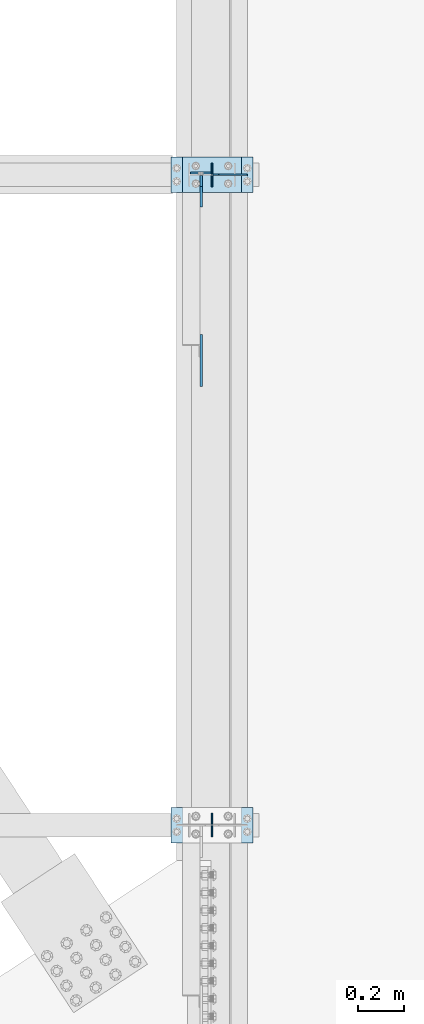
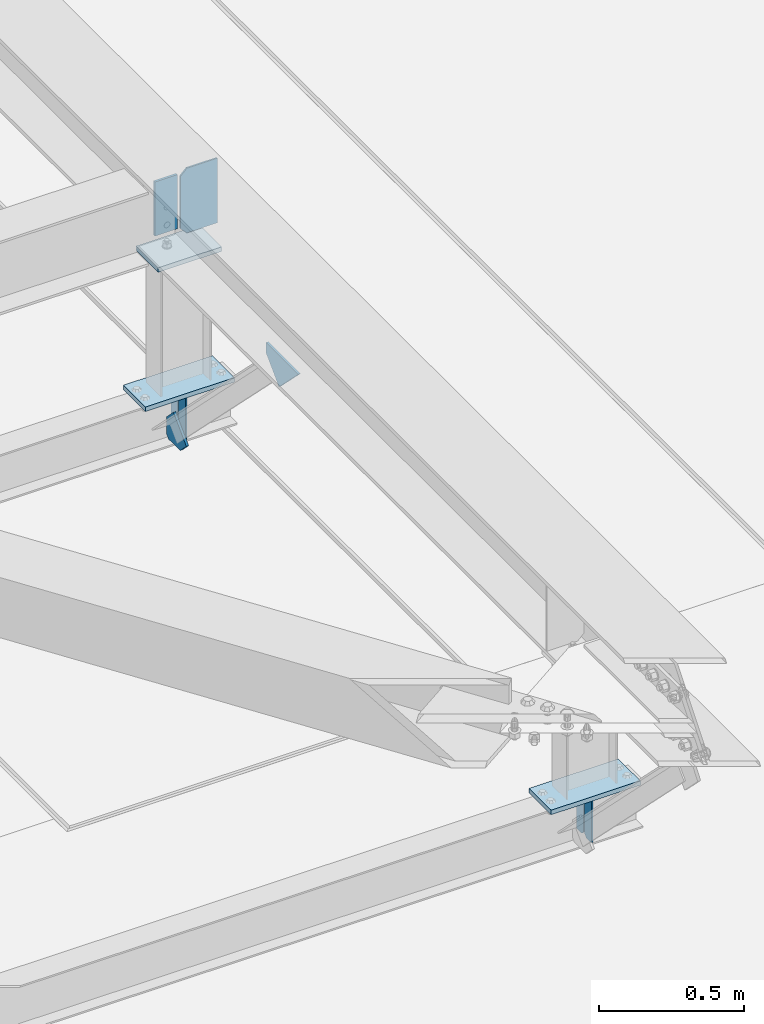
# One storey, part 3266 of 3843: 11 plates, 5 elements without a shape of their own.
"""IFC2X3 building model written with IfcOpenShell, lengths in millimetres."""

from ifc_helpers import new_model, si_unit, frame, origin_with_axes, place, context, subcontext, project, spatial, faceted_brep, material, type_object, element, aggregate, save


model = new_model("IFC2X3")

# Units and contexts
model_context = context("Model", 3, precision=1e-05, world=origin_with_axes())
body_context = subcontext(model_context, "Body", "Model", "MODEL_VIEW")
ifc_project = project(units=[si_unit("LENGTHUNIT", "METRE", prefix="MILLI"), si_unit("AREAUNIT", "SQUARE_METRE"), si_unit("VOLUMEUNIT", "CUBIC_METRE"), si_unit("MASSUNIT", "GRAM", prefix="KILO"), si_unit("TIMEUNIT", "SECOND"), si_unit("PLANEANGLEUNIT", "RADIAN"), si_unit("SOLIDANGLEUNIT", "STERADIAN"), si_unit("THERMODYNAMICTEMPERATUREUNIT", "DEGREE_CELSIUS"), si_unit("LUMINOUSINTENSITYUNIT", "LUMEN")], contexts=[model_context])

# Site, building, storey
site_placement = place(None, origin_with_axes())
site = spatial("IfcSite", under=ifc_project, at=site_placement, CompositionType="ELEMENT")
building_placement = place(site_placement, origin_with_axes())
building = spatial("IfcBuilding", under=site, at=building_placement, Name="Undefined", CompositionType="ELEMENT")
storey_placement = place(building_placement, origin_with_axes())
storey = spatial("IfcBuildingStorey", under=building, at=storey_placement, Name="Undefined", CompositionType="ELEMENT", Elevation=0.0)

# Assembly, plate
assembly_1_placement = place(storey_placement, origin_with_axes())
assembly_1 = element("IfcElementAssembly", 1, at=assembly_1_placement, inside=storey, Name="BEAM", AssemblyPlace="NOTDEFINED", PredefinedType="RIGID_FRAME")
ifc_material = material(Name="STEEL/A572-50")
plate_type_1 = type_object("IfcPlateType", PredefinedType="NOTDEFINED")
plate_1_placement = place(assembly_1_placement, frame((42057.6375000001, 54744.9375, 42394.940947973), z_axis=(-1.0, 0.0, 0.0), x_axis=(0.0, 0.0, -1.0)))
plate_1 = element("IfcPlate", 2, at=plate_1_placement, type_object=plate_type_1, material=ifc_material, Name="PLATE", context=body_context, shape_type="Brep", body=[
    faceted_brep([(0.0, -4.76249999999709, 0.0), (0.0, -4.76249999999709, 88.9000015258789), (0.0, 4.76249999999709, 88.9000015258789), (0.0, 4.76249999999709, 0.0), (228.600006102781, -4.7625000004191, 88.9000015257589), (228.600006102781, 4.76249999954598, 88.9000015257443), (228.600006103079, -4.7625000004482, 7.27595761418343e-12), (228.600006103079, 4.76249999954598, -7.27595761418343e-12)], [[[0, 1, 2, 3]], [[1, 4, 5, 2]], [[4, 6, 7, 5]], [[6, 0, 3, 7]], [[5, 7, 3, 2]], [[6, 4, 1, 0]]]),
])

# Assembly, plates
assembly_2_placement = place(storey_placement, origin_with_axes())
assembly_2 = element("IfcElementAssembly", 3, at=assembly_2_placement, inside=storey, Name="BEAM", AssemblyPlace="NOTDEFINED", PredefinedType="RIGID_FRAME")
plate_type_2 = type_object("IfcPlateType", PredefinedType="NOTDEFINED")
plate_2_placement = place(assembly_2_placement, frame((42062.4, 51879.5, 41495.6625), z_axis=(0.0, 0.0, -1.0), x_axis=(0.0, 1.0, 0.0)))
plate_2 = element("IfcPlate", 4, at=plate_2_placement, type_object=plate_type_2, material=ifc_material, Name="PLATE", context=body_context, shape_type="Brep", body=[
    faceted_brep([(0.0, -3.17499999999927, 0.0), (0.0, -3.17500000000291, 187.324999999997), (0.0, 3.17500000000291, 187.324999999997), (0.0, 3.17499999999927, 0.0), (34.9250001907349, -3.17500000000291, 187.324999999997), (34.9250001907349, 3.17500000000291, 187.324999999997), (47.625, -3.17500000000291, 174.625000190732), (47.625, 3.17500000000291, 174.625000190732), (47.625, -3.17499999999927, 12.6999998092651), (47.625, 3.17499999999927, 12.6999998092651), (34.9250001907349, -3.17499999999927, 0.0), (34.9250001907349, 3.17499999999927, 0.0)], [[[0, 1, 2, 3]], [[1, 4, 5, 2]], [[4, 6, 7, 5]], [[6, 8, 9, 7]], [[8, 10, 11, 9]], [[10, 0, 3, 11]], [[5, 7, 9, 11, 3, 2]], [[10, 8, 6, 4, 1, 0]]]),
])
plate_3_placement = place(assembly_2_placement, frame((42062.4, 51981.1, 41495.6625), z_axis=(0.0, 0.0, -1.0), x_axis=(0.0, -1.0, 0.0)))
plate_3 = element("IfcPlate", 5, at=plate_3_placement, type_object=plate_type_2, material=ifc_material, Name="PLATE", context=body_context, shape_type="Brep", body=[
    faceted_brep([(0.0, -3.17499999999927, 0.0), (0.0, -3.17500000000291, 187.324999999997), (0.0, 3.17500000000291, 187.324999999997), (0.0, 3.17499999999927, 0.0), (34.9250001907349, -3.17500000000291, 187.324999999997), (34.9250001907349, 3.17500000000291, 187.324999999997), (47.625, -3.17500000000291, 174.625000190732), (47.625, 3.17500000000291, 174.625000190732), (47.625, -3.17499999999927, 12.6999998092651), (47.625, 3.17499999999927, 12.6999998092651), (34.9250001907349, -3.17499999999927, 0.0), (34.9250001907349, 3.17499999999927, 0.0)], [[[0, 1, 2, 3]], [[1, 4, 5, 2]], [[4, 6, 7, 5]], [[6, 8, 9, 7]], [[8, 10, 11, 9]], [[10, 0, 3, 11]], [[5, 7, 9, 11, 3, 2]], [[10, 8, 6, 4, 1, 0]]]),
])
aggregate(assembly_2, [plate_2, plate_3])

assembly_3_placement = place(storey_placement, origin_with_axes())
assembly_3 = element("IfcElementAssembly", 6, at=assembly_3_placement, inside=storey, Name="BEAM", AssemblyPlace="NOTDEFINED", PredefinedType="RIGID_FRAME")
plate_4_placement = place(assembly_3_placement, frame((42062.4, 54686.2, 41495.6625), z_axis=(0.0, 0.0, -1.0), x_axis=(0.0, 1.0, 0.0)))
plate_4 = element("IfcPlate", 7, at=plate_4_placement, type_object=plate_type_2, material=ifc_material, Name="PLATE", context=body_context, shape_type="Brep", body=[
    faceted_brep([(0.0, -3.17499999999927, 0.0), (0.0, -3.17500000000291, 187.324999999997), (0.0, 3.17500000000291, 187.324999999997), (0.0, 3.17499999999927, 0.0), (34.9250001907349, -3.17500000000291, 187.324999999997), (34.9250001907349, 3.17500000000291, 187.324999999997), (47.625, -3.17500000000291, 174.625000190732), (47.625, 3.17500000000291, 174.625000190732), (47.625, -3.17499999999927, 12.6999998092651), (47.625, 3.17499999999927, 12.6999998092651), (34.9250001907349, -3.17499999999927, 0.0), (34.9250001907349, 3.17499999999927, 0.0)], [[[0, 1, 2, 3]], [[1, 4, 5, 2]], [[4, 6, 7, 5]], [[6, 8, 9, 7]], [[8, 10, 11, 9]], [[10, 0, 3, 11]], [[5, 7, 9, 11, 3, 2]], [[10, 8, 6, 4, 1, 0]]]),
])
plate_5_placement = place(assembly_3_placement, frame((42062.4, 54787.8, 41495.6625), z_axis=(0.0, 0.0, -1.0), x_axis=(0.0, -1.0, 0.0)))
plate_5 = element("IfcPlate", 8, at=plate_5_placement, type_object=plate_type_2, material=ifc_material, Name="PLATE", context=body_context, shape_type="Brep", body=[
    faceted_brep([(0.0, -3.17499999999927, 0.0), (0.0, -3.17500000000291, 187.324999999997), (0.0, 3.17500000000291, 187.324999999997), (0.0, 3.17499999999927, 0.0), (34.9250001907349, -3.17500000000291, 187.324999999997), (34.9250001907349, 3.17500000000291, 187.324999999997), (47.625, -3.17500000000291, 174.625000190732), (47.625, 3.17500000000291, 174.625000190732), (47.625, -3.17499999999927, 12.6999998092651), (47.625, 3.17499999999927, 12.6999998092651), (34.9250001907349, -3.17499999999927, 0.0), (34.9250001907349, 3.17499999999927, 0.0)], [[[0, 1, 2, 3]], [[1, 4, 5, 2]], [[4, 6, 7, 5]], [[6, 8, 9, 7]], [[8, 10, 11, 9]], [[10, 0, 3, 11]], [[5, 7, 9, 11, 3, 2]], [[10, 8, 6, 4, 1, 0]]]),
])

# Assembly, plate
assembly_4_placement = place(storey_placement, origin_with_axes())
assembly_4 = element("IfcElementAssembly", 9, at=assembly_4_placement, inside=storey, Name="POST", AssemblyPlace="NOTDEFINED", PredefinedType="RIGID_FRAME")
plate_type_3 = type_object("IfcPlateType", PredefinedType="NOTDEFINED")
plate_6_placement = place(assembly_4_placement, frame((41935.3999969006, 54813.2007403097, 42083.0375000289), z_axis=(0.0, -0.999999996977702, -7.77469999939545e-05), x_axis=(1.0, 0.0, 0.0)))
plate_6 = element("IfcPlate", 10, at=plate_6_placement, type_object=plate_type_3, material=ifc_material, Name="PLATE", context=body_context, shape_type="Brep", body=[
    faceted_brep([(0.0, -9.52500000000146, 0.0), (0.0, -9.5249999999287, 152.40000000162), (0.0, 9.52500000002328, 152.40000000162), (0.0, 9.52500000000146, 0.0), (254.0, -9.5249999999287, 152.40000000162), (254.0, 9.52500000002328, 152.40000000162), (253.999999999998, -9.52500000000146, 0.0), (253.999999999998, 9.52500000000146, 0.0)], [[[0, 1, 2, 3]], [[1, 4, 5, 2]], [[4, 6, 7, 5]], [[6, 0, 3, 7]], [[5, 7, 3, 2]], [[6, 4, 1, 0]]]),
])

assembly_5_placement = place(storey_placement, origin_with_axes())
assembly_5 = element("IfcElementAssembly", 11, at=assembly_5_placement, inside=storey, Name="POST", AssemblyPlace="NOTDEFINED", PredefinedType="RIGID_FRAME")
plate_7_placement = place(assembly_5_placement, frame((42240.2, 51854.1, 41513.125), z_axis=(-1.0, 0.0, 0.0), x_axis=(0.0, 1.0, 0.0)))
plate_7 = element("IfcPlate", 12, at=plate_7_placement, type_object=plate_type_3, material=ifc_material, Name="PLATE", context=body_context, shape_type="Brep", body=[
    faceted_brep([(0.0, -9.52500000000146, 0.0), (0.0, -9.52500000000146, 355.599999999999), (0.0, 9.52500000000146, 355.599999999999), (0.0, 9.52500000000146, 0.0), (152.399999999994, -9.52500000000146, 355.599999999999), (152.399999999994, 9.52500000000146, 355.599999999999), (152.400000000001, -9.52500000000146, 0.0), (152.400000000001, 9.52500000000146, 0.0)], [[[0, 1, 2, 3]], [[1, 4, 5, 2]], [[4, 6, 7, 5]], [[6, 0, 3, 7]], [[5, 7, 3, 2]], [[6, 4, 1, 0]]]),
])
aggregate(assembly_5, [plate_7])

# Plate
plate_8_placement = place(assembly_4_placement, frame((42240.2, 54660.8, 41513.125), z_axis=(-1.0, 0.0, 0.0), x_axis=(0.0, 1.0, 0.0)))
plate_8 = element("IfcPlate", 13, at=plate_8_placement, type_object=plate_type_3, material=ifc_material, Name="PLATE", context=body_context, shape_type="Brep", body=[
    faceted_brep([(0.0, -9.52500000000146, 0.0), (0.0, -9.52500000000146, 355.599999999999), (0.0, 9.52500000000146, 355.599999999999), (0.0, 9.52500000000146, 0.0), (152.399999999994, -9.52500000000146, 355.599999999999), (152.399999999994, 9.52500000000146, 355.599999999999), (152.400000000001, -9.52500000000146, 0.0), (152.400000000001, 9.52500000000146, 0.0)], [[[0, 1, 2, 3]], [[1, 4, 5, 2]], [[4, 6, 7, 5]], [[6, 0, 3, 7]], [[5, 7, 3, 2]], [[6, 4, 1, 0]]]),
])

aggregate(assembly_4, [plate_6, plate_8])

plate_type_4 = type_object("IfcPlateType", PredefinedType="NOTDEFINED")
plate_9_placement = place(assembly_1_placement, frame((42016.3625, 53824.0897610718, 42123.4142163618), z_axis=(0.0, 0.707106781186548, 0.707106781186548), x_axis=(5.70000238222118e-08, 0.707106781186546, -0.707106781186546)))
plate_9 = element("IfcPlate", 14, at=plate_9_placement, type_object=plate_type_4, material=ifc_material, Name="PLATE", context=body_context, shape_type="Brep", body=[
    faceted_brep([(0.0, -4.76249999999709, 0.0), (157.726597423803, -4.76249999999709, 157.726601438866), (157.726597423803, 4.76249999999709, 157.726601438866), (0.0, 4.76249999999709, 0.0), (188.387110059113, -4.76249999999709, 127.066089584019), (188.387110059113, 4.76249999999709, 127.066089584019), (188.387111679331, -4.76249999999709, 1.09139364212751e-10), (188.387111679331, 4.76249999999709, 1.09139364212751e-10)], [[[0, 1, 2, 3]], [[1, 4, 5, 2]], [[4, 6, 7, 5]], [[6, 0, 3, 7]], [[5, 7, 3, 2]], [[6, 4, 1, 0]]]),
])

plate_type_5 = type_object("IfcPlateType", PredefinedType="NOTDEFINED")
plate_10_placement = place(assembly_3_placement, frame((42016.3625, 54733.8250000347, 41306.750000025), z_axis=(0.0, -1.0, 0.0), x_axis=(0.0, 0.0, 1.0)))
plate_10 = element("IfcPlate", 15, at=plate_10_placement, type_object=plate_type_5, material=ifc_material, Name="PLATE", context=body_context, shape_type="Brep", body=[
    faceted_brep([(0.0, -4.76250000000073, 12.6999998092651), (4.450703272596e-08, -4.76249999999709, 93.0710244828806), (4.450703272596e-08, 4.76249999999709, 93.0710244828806), (0.0, 4.76250000000073, 12.6999998092651), (43.3137807601452, -4.76249999999709, 136.384805065652), (43.3137807601452, 4.76249999999709, 136.384805065652), (133.209805202001, -4.76249999999709, 46.4887805392646), (133.209805202001, 4.76249999999709, 46.4887805392646), (86.7210245267561, -4.76249999999709, 0.0), (86.7210245267561, 4.76249999999709, 0.0), (12.6999998092651, -4.76250000000073, 0.0), (12.6999998092651, 4.76250000000073, 0.0)], [[[0, 1, 2, 3]], [[1, 4, 5, 2]], [[4, 6, 7, 5]], [[6, 8, 9, 7]], [[8, 10, 11, 9]], [[10, 0, 3, 11]], [[5, 7, 9, 11, 3, 2]], [[10, 8, 6, 4, 1, 0]]]),
])

aggregate(assembly_3, [plate_10, plate_4, plate_5])

plate_type_6 = type_object("IfcPlateType", PredefinedType="NOTDEFINED")
plate_11_placement = place(assembly_1_placement, frame((42214.8, 54736.9774135246, 42413.9907023795), z_axis=(0.0, 7.77469999957245e-05, -0.999999996977702), x_axis=(-1.0, 0.0, 0.0)))
plate_11 = element("IfcPlate", 16, at=plate_11_placement, type_object=plate_type_6, material=ifc_material, Name="PLATE", context=body_context, shape_type="Brep", body=[
    faceted_brep([(0.0, -3.17499999999927, 0.0), (0.0, -3.17500000007567, 273.049999997937), (0.0, 3.17499999993743, 273.049999997937), (0.0, 3.17499999999927, 0.0), (122.237500389827, -3.17500000007567, 273.049999997937), (122.237500389827, 3.17499999993743, 273.049999997937), (147.637500008357, -3.17500000006476, 247.650000379464), (147.637500008357, 3.17499999994106, 247.650000379464), (147.637500008357, -3.17500000001382, 25.3999996184648), (147.637500008357, 3.17499999999927, 25.3999996184648), (122.237500389827, -3.17500000000291, 0.0), (122.237500389827, 3.17500000000291, -7.27595761418343e-12)], [[[0, 1, 2, 3]], [[1, 4, 5, 2]], [[4, 6, 7, 5]], [[6, 8, 9, 7]], [[8, 10, 11, 9]], [[10, 0, 3, 11]], [[5, 7, 9, 11, 3, 2]], [[10, 8, 6, 4, 1, 0]]]),
])

aggregate(assembly_1, [plate_1, plate_11, plate_9])

save(model, "model.ifc")
